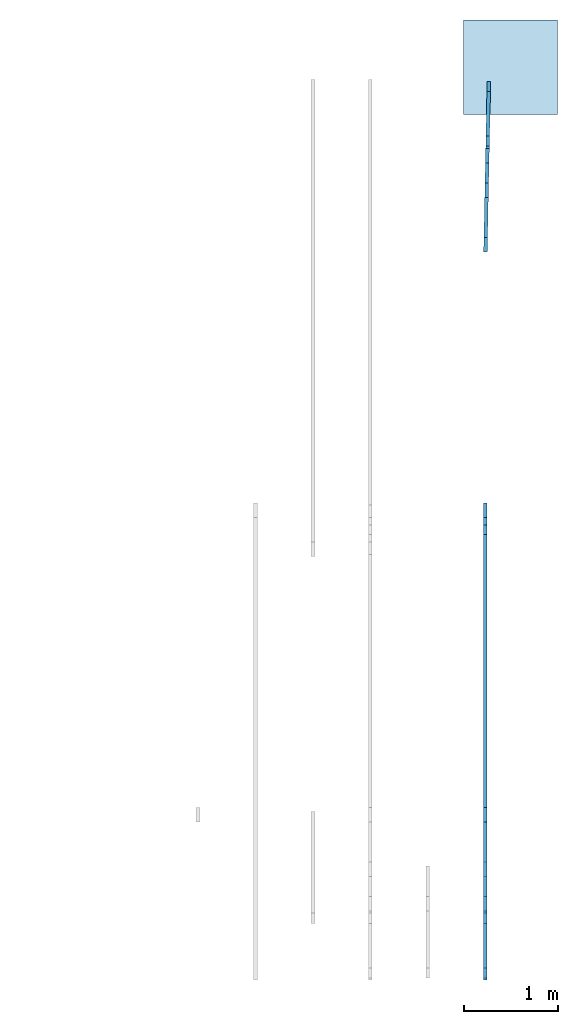
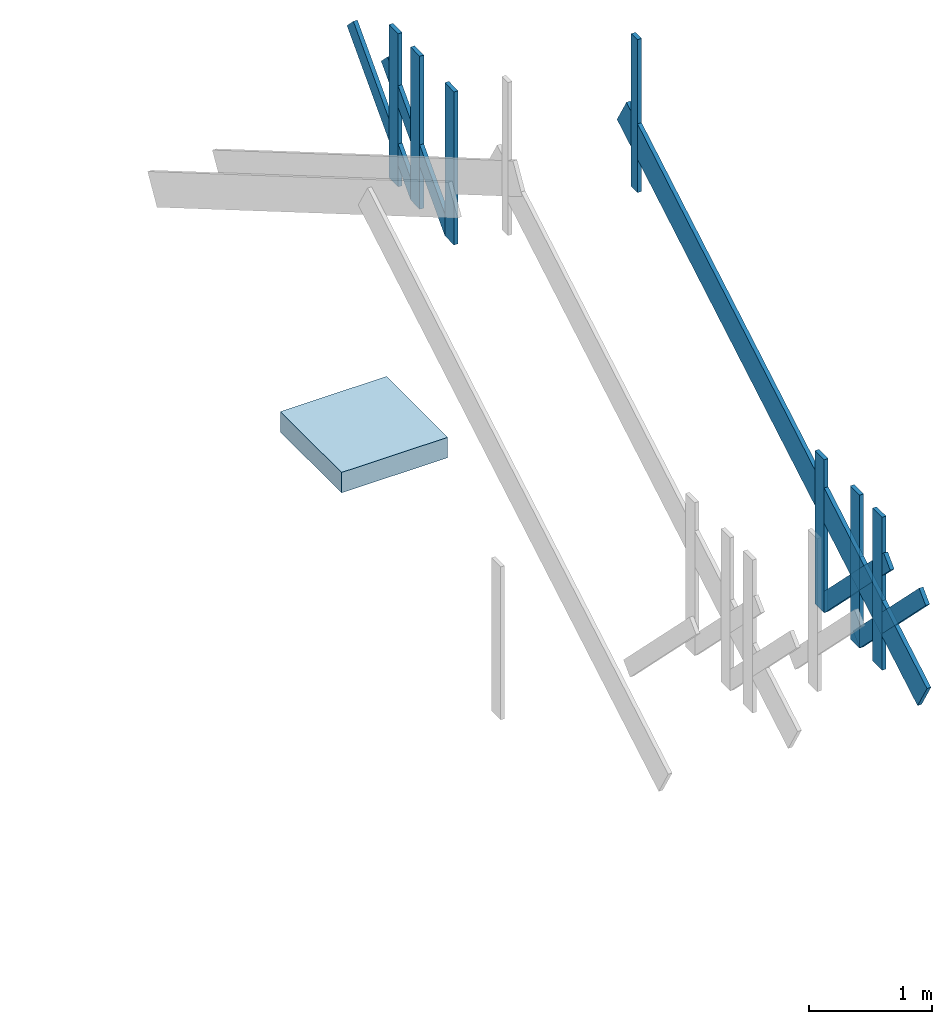
# One storey, part 2 of 2: 21 members, 1 slab.
"""IFC4 building model written with IfcOpenShell, lengths in inches."""

from ifc_helpers import new_model, entity, si_unit, converted_unit, frame, origin_with_axes, origin_2d_with_axis, place, context, subcontext, project, spatial, indexed_curve, outline, extrude, material, layer, layer_set, layer_usage, type_object, element, save


model = new_model("IFC4")

# Units and contexts
model_context = context("Model", 3, precision=1e-05, world=origin_with_axes())
plan_context = context("Plan", 2, precision=1e-05, world=origin_2d_with_axis())
body_context = subcontext(model_context, "Body", "Model", "MODEL_VIEW")
ifc_project = project(units=[converted_unit("PLANEANGLEUNIT", "degree", entity("IfcReal", 0.0174532925199433), si_unit("PLANEANGLEUNIT", "RADIAN"), dimensions=[0, 0, 0, 0, 0, 0, 0]), converted_unit("AREAUNIT", "square inch", entity("IfcReal", 0.0006452), si_unit("AREAUNIT", "SQUARE_METRE"), dimensions=[2, 0, 0, 0, 0, 0, 0]), converted_unit("LENGTHUNIT", "inch", entity("IfcReal", 0.0254), si_unit("LENGTHUNIT", "METRE"), dimensions=[1, 0, 0, 0, 0, 0, 0]), converted_unit("VOLUMEUNIT", "cubic inch", entity("IfcReal", 1.639e-05), si_unit("VOLUMEUNIT", "CUBIC_METRE"), dimensions=[3, 0, 0, 0, 0, 0, 0])], contexts=[model_context, plan_context])

# Site, building, storey
site_placement = place(None, origin_with_axes())
site = spatial("IfcSite", under=ifc_project, at=site_placement)
building_placement = place(site_placement, frame((0.0, 0.0, 109.012492998378), z_axis=(0.0, 0.0, 1.0), x_axis=(1.0, 0.0, 0.0)))
building = spatial("IfcBuilding", under=site, at=building_placement, Name="Building")
storey_placement = place(building_placement, frame((0.0, 0.0, -109.012492998378), z_axis=(0.0, 0.0, 1.0), x_axis=(1.0, 0.0, 0.0)))
storey = spatial("IfcBuildingStorey", under=building, at=storey_placement, Name="Roof")

# Members
ifc_material = material(Name="Default")
ifc_layer_1 = layer(ifc_material, 1.5)
ifc_layer_set_1 = layer_set([ifc_layer_1])
ifc_layer_usage_1 = layer_usage(ifc_layer_set_1, "AXIS2", "POSITIVE", 0.0)
member_type_1 = type_object("IfcMemberType", Name="2x12 wood rafter", PredefinedType="RAFTER", material=ifc_layer_set_1)
member_1_placement = place(storey_placement, frame((632.999900757797, -357.879090496874, 121.012494320006), z_axis=(2.75442979535967e-09, -0.504527628421783, 0.863395571708679), x_axis=(5.79808386191871e-07, 0.863395571708679, 0.504527628421783)))
element("IfcMember", 1, at=member_1_placement, inside=storey, type_object=member_type_1, material=ifc_layer_usage_1, Name="Member", PredefinedType="NOTDEFINED", context=body_context, shape_type="SweptSolid", body=[
    extrude(outline(indexed_curve([(0.0, 0.0), (0.0, 1.5), (223.635576889592, 1.5), (223.635576889592, 0.0), (0.0, 0.0)], self_intersect=False)), origin_with_axes(), (0.0, 0.0, 1.0), 12.0),
])
ifc_layer_usage_2 = layer_usage(ifc_layer_set_1, "AXIS2", "POSITIVE", 0.0)
member_2_placement = place(storey_placement, frame((632.999900757797, -357.879090496874, 121.012494320006), z_axis=(2.75442979535967e-09, -0.504527628421783, 0.863395571708679), x_axis=(5.79808386191871e-07, 0.863395571708679, 0.504527628421783)))
element("IfcMember", 2, at=member_2_placement, inside=storey, type_object=member_type_1, material=ifc_layer_usage_2, Name="Member", PredefinedType="NOTDEFINED", context=body_context, shape_type="SweptSolid", body=[
    extrude(outline(indexed_curve([(0.0, 0.0), (0.0, 1.5), (223.635576889592, 1.5), (223.635576889592, 0.0), (0.0, 0.0)], self_intersect=False)), origin_with_axes(), (0.0, 0.0, 1.0), 12.0),
])
ifc_layer_usage_3 = layer_usage(ifc_layer_set_1, "AXIS2", "POSITIVE", 0.0)
member_3_placement = place(storey_placement, frame((632.999900757797, -357.879090496874, 121.012494320006), z_axis=(2.75442979535967e-09, -0.504527628421783, 0.863395571708679), x_axis=(5.79808386191871e-07, 0.863395571708679, 0.504527628421783)))
element("IfcMember", 3, at=member_3_placement, inside=storey, type_object=member_type_1, material=ifc_layer_usage_3, Name="Member", PredefinedType="NOTDEFINED", context=body_context, shape_type="SweptSolid", body=[
    extrude(outline(indexed_curve([(0.0, 0.0), (0.0, 1.5), (223.635576889592, 1.5), (223.635576889592, 0.0), (0.0, 0.0)], self_intersect=False)), origin_with_axes(), (0.0, 0.0, 1.0), 12.0),
])
ifc_layer_2 = layer(ifc_material, 1.5, ventilated=False, Name="2x4 wood member")
ifc_layer_set_2 = layer_set([ifc_layer_2], Name="2x4 wood member")
ifc_layer_usage_4 = layer_usage(ifc_layer_set_2, "AXIS2", "POSITIVE", 0.0)
member_type_2 = type_object("IfcMemberType", Name="2x4 wood member", PredefinedType="NOTDEFINED", material=ifc_layer_set_2)
member_4_placement = place(storey_placement, frame((633.000050942729, -173.939550955465, 213.012507581335), z_axis=(4.37113882867379e-08, -1.0, -8.51092183247427e-15), x_axis=(1.94707183709397e-07, 0.0, 1.0)))
element("IfcMember", 4, at=member_4_placement, inside=storey, type_object=member_type_2, material=ifc_layer_usage_4, Name="Member", PredefinedType="NOTDEFINED", context=body_context, shape_type="SweptSolid", body=[
    extrude(outline(indexed_curve([(0.0, 0.0), (0.0, 1.5), (60.0000067531971, 1.5), (60.0000067531971, 0.0), (0.0, 0.0)], self_intersect=False)), origin_with_axes(), (0.0, 0.0, 1.0), 4.0),
])
ifc_layer_usage_5 = layer_usage(ifc_layer_set_2, "AXIS2", "POSITIVE", 0.0)
member_5_placement = place(storey_placement, frame((633.000050942729, -173.939550955465, 213.012507581335), z_axis=(4.37113882867379e-08, -1.0, -8.51092183247427e-15), x_axis=(1.94707183709397e-07, 0.0, 1.0)))
element("IfcMember", 5, at=member_5_placement, inside=storey, type_object=member_type_2, material=ifc_layer_usage_5, Name="Member", PredefinedType="NOTDEFINED", context=body_context, shape_type="SweptSolid", body=[
    extrude(outline(indexed_curve([(0.0, 0.0), (0.0, 1.5), (60.0000067531971, 1.5), (60.0000067531971, 0.0), (0.0, 0.0)], self_intersect=False)), origin_with_axes(), (0.0, 0.0, 1.0), 4.0),
])
ifc_layer_usage_6 = layer_usage(ifc_layer_set_2, "AXIS2", "POSITIVE", 0.0)
member_6_placement = place(storey_placement, frame((633.000050942729, -173.939550955465, 213.012507581335), z_axis=(4.37113882867379e-08, -1.0, -8.51092183247427e-15), x_axis=(1.94707183709397e-07, 0.0, 1.0)))
element("IfcMember", 6, at=member_6_placement, inside=storey, type_object=member_type_2, material=ifc_layer_usage_6, Name="Member", PredefinedType="NOTDEFINED", context=body_context, shape_type="SweptSolid", body=[
    extrude(outline(indexed_curve([(0.0, 0.0), (0.0, 1.5), (60.0000067531971, 1.5), (60.0000067531971, 0.0), (0.0, 0.0)], self_intersect=False)), origin_with_axes(), (0.0, 0.0, 1.0), 4.0),
])
ifc_layer_3 = layer(ifc_material, 1.5, Name="2x6 wood member")
ifc_layer_set_3 = layer_set([ifc_layer_3])
ifc_layer_usage_7 = layer_usage(ifc_layer_set_3, "AXIS2", "POSITIVE", 0.0)
member_type_3 = type_object("IfcMemberType", Name="2x6 wood member", PredefinedType="NOTDEFINED", material=ifc_layer_set_3)
member_7_placement = place(storey_placement, frame((632.999900757797, -291.879083227924, 121.012494320006), z_axis=(4.37113882867379e-08, -1.0, -8.51092183247427e-15), x_axis=(1.94707183709397e-07, 0.0, 1.0)))
element("IfcMember", 7, at=member_7_placement, inside=storey, type_object=member_type_3, material=ifc_layer_usage_7, Name="Member", PredefinedType="NOTDEFINED", context=body_context, shape_type="SweptSolid", body=[
    extrude(outline(indexed_curve([(0.0, 0.0), (0.0, 1.5), (60.0000067531971, 1.5), (60.0000067531971, 0.0), (0.0, 0.0)], self_intersect=False)), origin_with_axes(), (0.0, 0.0, 1.0), 6.0),
])
ifc_layer_usage_8 = layer_usage(ifc_layer_set_3, "AXIS2", "POSITIVE", 0.0)
member_8_placement = place(storey_placement, frame((631.536048228346, -58.2341415675606, 125.25514354856), z_axis=(0.01430035661906, 0.706962108612061, -0.707106709480286), x_axis=(0.0142999459058046, 0.706962108612061, 0.707106709480286)))
element("IfcMember", 8, at=member_8_placement, inside=storey, type_object=member_type_3, material=ifc_layer_usage_8, Name="Member", PredefinedType="NOTDEFINED", context=body_context, shape_type="SweptSolid", body=[
    extrude(outline(indexed_curve([(0.0, 0.0), (0.0, 1.5), (60.0000067531971, 1.5), (60.0000067531971, 0.0), (0.0, 0.0)], self_intersect=False)), origin_with_axes(), (0.0, 0.0, 1.0), 6.0),
])
ifc_layer_usage_9 = layer_usage(ifc_layer_set_3, "AXIS2", "POSITIVE", 0.0)
member_9_placement = place(storey_placement, frame((631.500379307064, -59.9911456971657, 121.012494320006), z_axis=(0.0202241335064173, 0.999795496463776, -3.93778432083991e-09), x_axis=(1.94707183709397e-07, 0.0, 1.0)))
element("IfcMember", 9, at=member_9_placement, inside=storey, type_object=member_type_3, material=ifc_layer_usage_9, Name="Member", PredefinedType="NOTDEFINED", context=body_context, shape_type="SweptSolid", body=[
    extrude(outline(indexed_curve([(0.0, 0.0), (0.0, 1.5), (60.0000067531971, 1.5), (60.0000067531971, 0.0), (0.0, 0.0)], self_intersect=False)), origin_with_axes(), (0.0, 0.0, 1.0), 6.0),
])
ifc_layer_usage_10 = layer_usage(ifc_layer_set_3, "AXIS2", "POSITIVE", 0.0)
member_10_placement = place(storey_placement, frame((631.960996492641, -37.2218452100679, 121.012494320006), z_axis=(0.0202241335064173, 0.999795496463776, -3.93778432083991e-09), x_axis=(1.94707183709397e-07, 0.0, 1.0)))
element("IfcMember", 10, at=member_10_placement, inside=storey, type_object=member_type_3, material=ifc_layer_usage_10, Name="Member", PredefinedType="NOTDEFINED", context=body_context, shape_type="SweptSolid", body=[
    extrude(outline(indexed_curve([(0.0, 0.0), (0.0, 1.5), (60.0000067531971, 1.5), (60.0000067531971, 0.0), (0.0, 0.0)], self_intersect=False)), origin_with_axes(), (0.0, 0.0, 1.0), 6.0),
])
ifc_layer_usage_11 = layer_usage(ifc_layer_set_3, "AXIS2", "POSITIVE", 0.0)
member_11_placement = place(storey_placement, frame((631.996590321458, -35.4648504670211, 125.255134162002), z_axis=(0.0143004665151238, 0.706962108612061, -0.707106709480286), x_axis=(0.0142999459058046, 0.706962108612061, 0.707106709480286)))
element("IfcMember", 11, at=member_11_placement, inside=storey, type_object=member_type_3, material=ifc_layer_usage_11, Name="Member", PredefinedType="NOTDEFINED", context=body_context, shape_type="SweptSolid", body=[
    extrude(outline(indexed_curve([(0.0, 0.0), (0.0, 1.5), (60.0000067531971, 1.5), (60.0000067531971, 0.0), (0.0, 0.0)], self_intersect=False)), origin_with_axes(), (0.0, 0.0, 1.0), 6.0),
])
ifc_layer_usage_12 = layer_usage(ifc_layer_set_3, "AXIS2", "POSITIVE", 0.0)
member_12_placement = place(storey_placement, frame((632.25167942798, -22.850470749412, 121.012494320006), z_axis=(0.0202241335064173, 0.999795496463776, -3.93778432083991e-09), x_axis=(1.94707183709397e-07, 0.0, 1.0)))
element("IfcMember", 12, at=member_12_placement, inside=storey, type_object=member_type_3, material=ifc_layer_usage_12, Name="Member", PredefinedType="NOTDEFINED", context=body_context, shape_type="SweptSolid", body=[
    extrude(outline(indexed_curve([(0.0, 0.0), (0.0, 1.5), (60.0000067531971, 1.5), (60.0000067531971, 0.0), (0.0, 0.0)], self_intersect=False)), origin_with_axes(), (0.0, 0.0, 1.0), 6.0),
])
ifc_layer_usage_13 = layer_usage(ifc_layer_set_3, "AXIS2", "POSITIVE", 0.0)
member_13_placement = place(storey_placement, frame((632.999900757797, -291.879083227924, 121.012494320006), z_axis=(4.37113882867379e-08, -1.0, -8.51092183247427e-15), x_axis=(1.94707183709397e-07, 0.0, 1.0)))
element("IfcMember", 13, at=member_13_placement, inside=storey, type_object=member_type_3, material=ifc_layer_usage_13, Name="Member", PredefinedType="NOTDEFINED", context=body_context, shape_type="SweptSolid", body=[
    extrude(outline(indexed_curve([(0.0, 0.0), (0.0, 1.5), (60.0000067531971, 1.5), (60.0000067531971, 0.0), (0.0, 0.0)], self_intersect=False)), origin_with_axes(), (0.0, 0.0, 1.0), 6.0),
])
ifc_layer_usage_14 = layer_usage(ifc_layer_set_3, "AXIS2", "POSITIVE", 0.0)
member_14_placement = place(storey_placement, frame((632.999825665331, -316.410402613362, 125.255134162002), z_axis=(6.26377456569571e-08, -0.707106709480286, -0.707106709480286), x_axis=(1.99495985953035e-07, -0.707106709480286, 0.707106709480286)))
element("IfcMember", 14, at=member_14_placement, inside=storey, type_object=member_type_3, material=ifc_layer_usage_14, Name="Member", PredefinedType="NOTDEFINED", context=body_context, shape_type="SweptSolid", body=[
    extrude(outline(indexed_curve([(0.0, 0.0), (0.0, 1.5), (60.0000067531971, 1.5), (60.0000067531971, 0.0), (0.0, 0.0)], self_intersect=False)), origin_with_axes(), (0.0, 0.0, 1.0), 6.0),
])
ifc_layer_usage_15 = layer_usage(ifc_layer_set_3, "AXIS2", "POSITIVE", 0.0)
member_15_placement = place(storey_placement, frame((632.999900757797, -329.027363634485, 121.012494320006), z_axis=(4.37113882867379e-08, -1.0, -8.51092183247427e-15), x_axis=(1.94707183709397e-07, 0.0, 1.0)))
element("IfcMember", 15, at=member_15_placement, inside=storey, type_object=member_type_3, material=ifc_layer_usage_15, Name="Member", PredefinedType="NOTDEFINED", context=body_context, shape_type="SweptSolid", body=[
    extrude(outline(indexed_curve([(0.0, 0.0), (0.0, 1.5), (60.0000067531971, 1.5), (60.0000067531971, 0.0), (0.0, 0.0)], self_intersect=False)), origin_with_axes(), (0.0, 0.0, 1.0), 6.0),
])
ifc_layer_usage_16 = layer_usage(ifc_layer_set_3, "AXIS2", "POSITIVE", 0.0)
member_16_placement = place(storey_placement, frame((632.999825665331, -293.6364534333, 125.25514354856), z_axis=(9.1863917361934e-08, -0.707106709480286, -0.707106709480286), x_axis=(2.83789688637626e-07, -0.707106709480286, 0.707106709480286)))
element("IfcMember", 16, at=member_16_placement, inside=storey, type_object=member_type_3, material=ifc_layer_usage_16, Name="Member", PredefinedType="NOTDEFINED", context=body_context, shape_type="SweptSolid", body=[
    extrude(outline(indexed_curve([(0.0, 0.0), (0.0, 1.5), (60.0000067531971, 1.5), (60.0000067531971, 0.0), (0.0, 0.0)], self_intersect=False)), origin_with_axes(), (0.0, 0.0, 1.0), 6.0),
])
ifc_layer_usage_17 = layer_usage(ifc_layer_set_3, "AXIS2", "POSITIVE", 0.0)
member_17_placement = place(storey_placement, frame((632.999900757797, -291.879083227924, 121.012494320006), z_axis=(4.37113882867379e-08, -1.0, -8.51092183247427e-15), x_axis=(1.94707183709397e-07, 0.0, 1.0)))
element("IfcMember", 17, at=member_17_placement, inside=storey, type_object=member_type_3, material=ifc_layer_usage_17, Name="Member", PredefinedType="NOTDEFINED", context=body_context, shape_type="SweptSolid", body=[
    extrude(outline(indexed_curve([(0.0, 0.0), (0.0, 1.5), (60.0000067531971, 1.5), (60.0000067531971, 0.0), (0.0, 0.0)], self_intersect=False)), origin_with_axes(), (0.0, 0.0, 1.0), 6.0),
])
ifc_layer_usage_18 = layer_usage(ifc_layer_set_3, "AXIS2", "POSITIVE", 0.0)
member_18_placement = place(storey_placement, frame((632.999900757797, -314.653051181102, 121.012494320006), z_axis=(4.37113882867379e-08, -1.0, -8.51092183247427e-15), x_axis=(1.94707183709397e-07, 0.0, 1.0)))
element("IfcMember", 18, at=member_18_placement, inside=storey, type_object=member_type_3, material=ifc_layer_usage_18, Name="Member", PredefinedType="NOTDEFINED", context=body_context, shape_type="SweptSolid", body=[
    extrude(outline(indexed_curve([(0.0, 0.0), (0.0, 1.5), (60.0000067531971, 1.5), (60.0000067531971, 0.0), (0.0, 0.0)], self_intersect=False)), origin_with_axes(), (0.0, 0.0, 1.0), 6.0),
])
ifc_layer_usage_19 = layer_usage(ifc_layer_set_3, "AXIS2", "POSITIVE", 0.0)
member_19_placement = place(storey_placement, frame((632.999825665331, -316.410402613362, 125.255134162002), z_axis=(6.26377456569571e-08, -0.707106709480286, -0.707106709480286), x_axis=(1.99495985953035e-07, -0.707106709480286, 0.707106709480286)))
element("IfcMember", 19, at=member_19_placement, inside=storey, type_object=member_type_3, material=ifc_layer_usage_19, Name="Member", PredefinedType="NOTDEFINED", context=body_context, shape_type="SweptSolid", body=[
    extrude(outline(indexed_curve([(0.0, 0.0), (0.0, 1.5), (60.0000067531971, 1.5), (60.0000067531971, 0.0), (0.0, 0.0)], self_intersect=False)), origin_with_axes(), (0.0, 0.0, 1.0), 6.0),
])
ifc_layer_usage_20 = layer_usage(ifc_layer_set_3, "AXIS2", "POSITIVE", 0.0)
member_20_placement = place(storey_placement, frame((632.999900757797, -329.027363634485, 121.012494320006), z_axis=(4.37113882867379e-08, -1.0, -8.51092183247427e-15), x_axis=(1.94707183709397e-07, 0.0, 1.0)))
element("IfcMember", 20, at=member_20_placement, inside=storey, type_object=member_type_3, material=ifc_layer_usage_20, Name="Member", PredefinedType="NOTDEFINED", context=body_context, shape_type="SweptSolid", body=[
    extrude(outline(indexed_curve([(0.0, 0.0), (0.0, 1.5), (60.0000067531971, 1.5), (60.0000067531971, 0.0), (0.0, 0.0)], self_intersect=False)), origin_with_axes(), (0.0, 0.0, 1.0), 6.0),
])
ifc_layer_usage_21 = layer_usage(ifc_layer_set_3, "AXIS2", "POSITIVE", 0.0)
member_21_placement = place(storey_placement, frame((632.999825665331, -293.6364534333, 125.25514354856), z_axis=(9.1863917361934e-08, -0.707106709480286, -0.707106709480286), x_axis=(2.83789688637626e-07, -0.707106709480286, 0.707106709480286)))
element("IfcMember", 21, at=member_21_placement, inside=storey, type_object=member_type_3, material=ifc_layer_usage_21, Name="Member", PredefinedType="NOTDEFINED", context=body_context, shape_type="SweptSolid", body=[
    extrude(outline(indexed_curve([(0.0, 0.0), (0.0, 1.5), (60.0000067531971, 1.5), (60.0000067531971, 0.0), (0.0, 0.0)], self_intersect=False)), origin_with_axes(), (0.0, 0.0, 1.0), 6.0),
])

# Slab
ifc_layer_4 = layer(ifc_material, 8.0, Name="8in concrete slab")
ifc_layer_set_4 = layer_set([ifc_layer_4], Name="8in concrete slab")
ifc_layer_usage_22 = layer_usage(ifc_layer_set_4, "AXIS3", "POSITIVE", 0.0)
slab_type = type_object("IfcSlabType", Name="8in concrete slab", PredefinedType="BASESLAB", material=ifc_layer_set_4)
slab_placement = place(storey_placement, frame((623.000174995482, -2.57912583238497, -7.99999990331845), z_axis=(0.0, 0.0, 1.0), x_axis=(1.0, 0.0, 0.0)))
element("IfcSlab", 22, at=slab_placement, inside=storey, type_object=slab_type, material=ifc_layer_usage_22, Name="Slab", PredefinedType="NOTDEFINED", context=body_context, shape_type="SweptSolid", body=[
    extrude(outline(indexed_curve([(0.0, 0.0), (39.3700787401575, 0.0), (39.3700787401575, 39.3700787401575), (0.0, 39.3700787401575), (0.0, 0.0)])), None, (0.0, 0.0, 1.0), 8.0),
])

save(model, "model.ifc")
